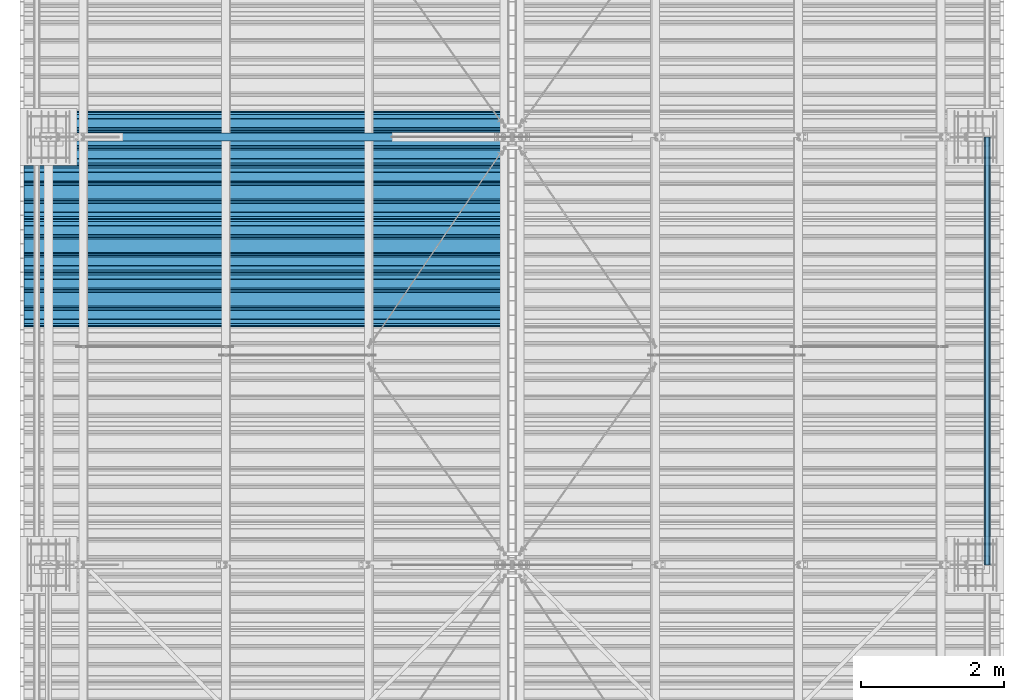
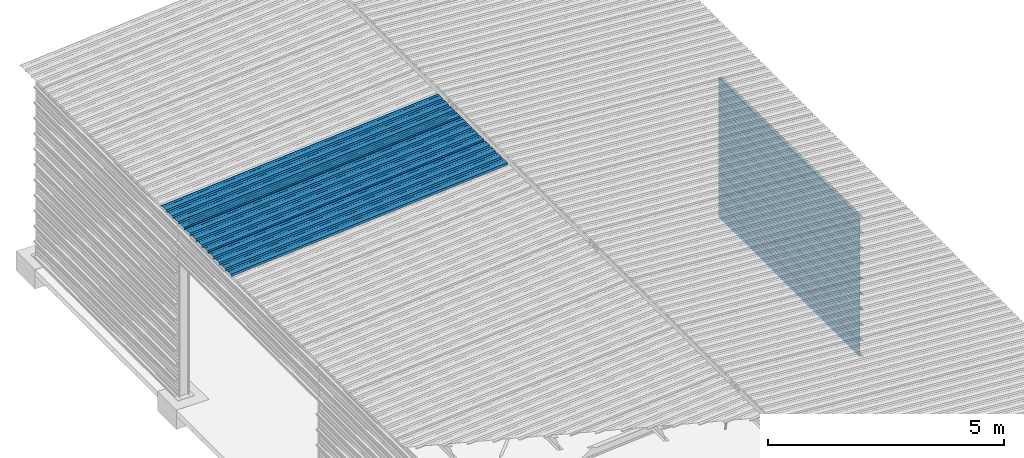
# One storey, part 15 of 70: 13 beams, 13 elements without a shape of their own.
"""IFC2X3 building model written with IfcOpenShell, lengths in millimetres."""

import ifcopenshell
import ifcopenshell.guid

model = None  # the IFC model being written
_history = None  # IfcOwnerHistory: only IFC2X3 demands one
_inside = {}  # id of a spatial element -> (the spatial element, [elements in it])
_under = {}  # id of a project, library or spatial element -> (it, [spatial elements below it])
_declared = {}  # id of a project -> (the project, [libraries it declares])
_typed = {}  # id of a type object -> (the type object, [elements of that type])
_made_of = {}  # id of a material, layer set ... -> (it, [elements and type objects made of it])


def new_model(schema):
    """Start an empty IFC model of exactly this schema.

    Asked for "IFC4X3", IfcOpenShell would pick the latest addendum, in which some entities
    have other attributes; the version numbers below select the first issue.
    IFC2X3 requires an IfcOwnerHistory on every rooted entity: one is made here for all.
    """
    global model, _history
    if schema == "IFC4X3":
        model = ifcopenshell.file(schema_version=(4, 3, 0, 0))
    else:
        model = ifcopenshell.file(schema=schema)
    _inside.clear()
    _under.clear()
    _declared.clear()
    _typed.clear()
    _made_of.clear()
    _history = None
    if model.schema == "IFC2X3":
        org = make("IfcOrganization", Name="unknown")
        user = make(
            "IfcPersonAndOrganization",
            ThePerson=make("IfcPerson", FamilyName="unknown"),
            TheOrganization=org,
        )
        app = make(
            "IfcApplication",
            ApplicationDeveloper=org,
            Version="unknown",
            ApplicationFullName="unknown",
            ApplicationIdentifier="unknown",
        )
        _history = make(
            "IfcOwnerHistory",
            OwningUser=user,
            OwningApplication=app,
            ChangeAction="ADDED",
            CreationDate=0,
        )
    return model


def make(cls, **values):
    """One entity of the class cls with the attributes given. An attribute that is None is left unset."""
    return model.create_entity(
        cls, **{name: value for name, value in values.items() if value is not None}
    )


def rooted(cls, **values):
    """An entity with a GlobalId (a new one), such as an element, a storey or a relation."""
    return make(cls, GlobalId=ifcopenshell.guid.new(), OwnerHistory=_history, **values)


def si_unit(unit_type, name, prefix=None):
    """IfcSIUnit, for example si_unit("LENGTHUNIT", "METRE", prefix="MILLI")."""
    return make("IfcSIUnit", UnitType=unit_type, Prefix=prefix, Name=name)


def assignment(units):
    """IfcUnitAssignment: the units of a project."""
    return None if units is None else make("IfcUnitAssignment", Units=units)


def point(xyz):
    """IfcCartesianPoint."""
    return None if xyz is None else make("IfcCartesianPoint", Coordinates=xyz)


def direction(xyz):
    """IfcDirection."""
    return None if xyz is None else make("IfcDirection", DirectionRatios=xyz)


def frame(location, z_axis=None, x_axis=None):
    """IfcAxis2Placement3D, a coordinate frame: its origin and axes. An axis left out is left unset."""
    return make(
        "IfcAxis2Placement3D",
        Location=point(location),
        Axis=direction(z_axis),
        RefDirection=direction(x_axis),
    )


def frame_2d(location, x_axis=None):
    """IfcAxis2Placement2D, a coordinate frame in the plane: its origin and x axis."""
    return make(
        "IfcAxis2Placement2D", Location=point(location), RefDirection=direction(x_axis)
    )


def origin_with_axes():
    """The frame at (0, 0, 0) with the z axis (0, 0, 1) and the x axis (1, 0, 0) written out."""
    return frame((0.0, 0.0, 0.0), z_axis=(0.0, 0.0, 1.0), x_axis=(1.0, 0.0, 0.0))


def origin_2d_with_axis():
    """The frame at (0, 0) in the plane with the x axis (1, 0) written out."""
    return frame_2d((0.0, 0.0), x_axis=(1.0, 0.0))


def place(relative_to, where):
    """IfcLocalPlacement: puts the frame where relative to a parent placement (None: the world)."""
    return make(
        "IfcLocalPlacement", PlacementRelTo=relative_to, RelativePlacement=where
    )


def context(
    kind, dimensions, precision=None, world=None, true_north=None, identifier=None
):
    """IfcGeometricRepresentationContext, for example the 3D "Model" context."""
    return make(
        "IfcGeometricRepresentationContext",
        ContextIdentifier=identifier,
        ContextType=kind,
        CoordinateSpaceDimension=dimensions,
        Precision=precision,
        WorldCoordinateSystem=world,
        TrueNorth=true_north,
    )


def subcontext(parent, identifier, kind, view, scale=None):
    """IfcGeometricRepresentationSubContext, for example "Body" below "Model"."""
    return make(
        "IfcGeometricRepresentationSubContext",
        ContextIdentifier=identifier,
        ContextType=kind,
        ParentContext=parent,
        TargetScale=scale,
        TargetView=view,
    )


def project(units=None, contexts=None):
    """IfcProject with its units and contexts."""
    return rooted(
        "IfcProject",
        Name="project",
        RepresentationContexts=contexts,
        UnitsInContext=assignment(units),
    )


def spatial(cls, under=None, at=None, **own):
    """A site, building, storey or space (cls), placed at a placement, below another one or the project."""
    s = rooted(cls, ObjectPlacement=at, **own)
    if under is not None:
        _under.setdefault(under.id(), (under, []))[1].append(s)
    return s


def polyline(points):
    """IfcPolyline through the points."""
    return make("IfcPolyline", Points=[point(p) for p in points])


def profile(cls, at=None, kind="AREA", **sizes):
    """A parametric profile (cls). Its sizes go by their IFC names, for example OverallWidth=200.0."""
    return make(cls, ProfileType=kind, Position=at, **sizes)


def i_section(**sizes):
    """IfcIShapeProfileDef."""
    return profile("IfcIShapeProfileDef", **sizes)


def outline(outer, holes=None, kind="AREA"):
    """IfcArbitraryClosedProfileDef: a profile drawn as a closed curve; with holes, ...WithVoids."""
    if holes is None:
        return make("IfcArbitraryClosedProfileDef", ProfileType=kind, OuterCurve=outer)
    return make(
        "IfcArbitraryProfileDefWithVoids",
        ProfileType=kind,
        OuterCurve=outer,
        InnerCurves=holes,
    )


def extrude(swept, where, along, depth):
    """IfcExtrudedAreaSolid: the profile swept, set in the frame where, extruded along a direction by depth."""
    return make(
        "IfcExtrudedAreaSolid",
        SweptArea=swept,
        Position=where,
        ExtrudedDirection=direction(along),
        Depth=depth,
    )


def clip(a, b, op="DIFFERENCE"):
    """IfcBooleanClippingResult: the solid a cut by the half space b."""
    return make(
        "IfcBooleanClippingResult", Operator=op, FirstOperand=a, SecondOperand=b
    )


def halfspace(plane, agree):
    """IfcHalfSpaceSolid: all space on one side of the plane z = 0 of the frame plane."""
    return make(
        "IfcHalfSpaceSolid",
        BaseSurface=make("IfcPlane", Position=plane),
        AgreementFlag=agree,
    )


def shape(context_of_items, identifier, shape_type, items):
    """IfcShapeRepresentation: the items that make up one representation, for example the "Body"."""
    return make(
        "IfcShapeRepresentation",
        ContextOfItems=context_of_items,
        RepresentationIdentifier=identifier,
        RepresentationType=shape_type,
        Items=items,
    )


def material(Name=None, Category=None):
    """IfcMaterial."""
    return make("IfcMaterial", Name=Name, Category=Category)


def made_of(thing, what):
    """Note that an element or type object is made of a material, layer set ...; save() writes the relation."""
    if what is not None:
        _made_of.setdefault(what.id(), (what, []))[1].append(thing)
    return thing


def type_object(cls, material=None, **own):
    """A type object (cls), such as IfcWallType, which elements share."""
    return made_of(rooted(cls, **own), material)


def element(
    cls,
    number,
    at=None,
    inside=None,
    cuts=None,
    type_object=None,
    material=None,
    context=None,
    identifier="Body",
    shape_type=None,
    held_by="IfcProductDefinitionShape",
    body=None,
    shapes=None,
    **own,
):
    """One element of the class cls, such as IfcWall. Its Tag is "e" and its number.

    at: its placement. inside: the storey or other place that contains it. cuts: it is an
    opening in that element (IfcRelVoidsElement). A single representation is given by context,
    identifier, shape_type and body (its items); several are given by shapes. held_by: the class
    of the entity that holds the representations. save() writes the other relations.
    """
    e = rooted(cls, Tag="e%d" % number, ObjectPlacement=at, **own)
    if body is not None:
        shapes = [shape(context, identifier, shape_type, body)]
    if shapes is not None:
        e.Representation = make(held_by, Representations=shapes)
    if inside is not None:
        _inside.setdefault(inside.id(), (inside, []))[1].append(e)
    if cuts is not None:
        rooted(
            "IfcRelVoidsElement", RelatingBuildingElement=cuts, RelatedOpeningElement=e
        )
    if type_object is not None:
        _typed.setdefault(type_object.id(), (type_object, []))[1].append(e)
    return made_of(e, material)


def aggregate(whole, parts):
    """IfcRelAggregates: a whole, such as a stair, and the parts it consists of."""
    return rooted("IfcRelAggregates", RelatingObject=whole, RelatedObjects=parts)


def save(model, path):
    """Write the relations noted so far, then the file.

    IfcRelAggregates (storeys below a building ...), IfcRelContainedInSpatialStructure (elements
    in a storey), IfcRelDefinesByType, IfcRelAssociatesMaterial and IfcRelDeclares: one each for
    every whole, place, type object, material and project.
    """
    for whole, parts in _under.values():
        aggregate(whole, parts)
    for where, things in _inside.values():
        rooted(
            "IfcRelContainedInSpatialStructure",
            RelatedElements=things,
            RelatingStructure=where,
        )
    for kind, things in _typed.values():
        rooted("IfcRelDefinesByType", RelatedObjects=things, RelatingType=kind)
    for what, things in _made_of.values():
        rooted("IfcRelAssociatesMaterial", RelatedObjects=things, RelatingMaterial=what)
    for by, libraries in _declared.values():
        rooted("IfcRelDeclares", RelatingContext=by, RelatedDefinitions=libraries)
    model.write(path)


model = new_model("IFC2X3")

# Units and contexts
model_context = context("Model", 3, precision=1e-05, world=origin_with_axes())
body_context = subcontext(model_context, "Body", "Model", "MODEL_VIEW")
ifc_project = project(units=[si_unit("LENGTHUNIT", "METRE", prefix="MILLI"), si_unit("AREAUNIT", "SQUARE_METRE"), si_unit("VOLUMEUNIT", "CUBIC_METRE"), si_unit("MASSUNIT", "GRAM", prefix="KILO"), si_unit("TIMEUNIT", "SECOND"), si_unit("PLANEANGLEUNIT", "RADIAN"), si_unit("SOLIDANGLEUNIT", "STERADIAN"), si_unit("THERMODYNAMICTEMPERATUREUNIT", "DEGREE_CELSIUS"), si_unit("LUMINOUSINTENSITYUNIT", "LUMEN")], contexts=[model_context])

# Site, building, storey
site_placement = place(None, origin_with_axes())
site = spatial("IfcSite", under=ifc_project, at=site_placement, CompositionType="ELEMENT")
building_placement = place(site_placement, origin_with_axes())
building = spatial("IfcBuilding", under=site, at=building_placement, Name="Undefined", CompositionType="ELEMENT")
storey_placement = place(building_placement, origin_with_axes())
storey = spatial("IfcBuildingStorey", under=building, at=storey_placement, Name="Undefined", CompositionType="ELEMENT", Elevation=0.0)

# Assembly, beam
assembly_1_placement = place(storey_placement, origin_with_axes())
assembly_1 = element("IfcElementAssembly", 1, at=assembly_1_placement, inside=storey, Name="Steel Assembly", AssemblyPlace="NOTDEFINED", PredefinedType="RIGID_FRAME")
ifc_material = material(Name="STEEL/S235JR")
beam_type_1 = type_object("IfcBeamType", Name="4.40", PredefinedType="NOTDEFINED")
beam_1_placement = place(assembly_1_placement, frame((6436.39248868039, 15850.0, 5336.31760454388), z_axis=(0.0766964990376782, 0.0, -0.997054485489817), x_axis=(-0.997054485489818, 0.0, -0.0766964990376602)))
beam_1 = element("IfcBeam", 2, at=beam_1_placement, type_object=beam_type_1, material=ifc_material, ObjectType="4.40", context=body_context, shape_type="SweptSolid", body=[
    extrude(outline(polyline([(509.415161132813, 19.5000000011705), (490.584838867188, 19.5000000011705), (468.084838867188, -20.4999999988113), (406.585784912109, -20.4999999988113), (404.585784912109, -18.4999999988122), (345.414215087891, -18.4999999988122), (343.414215087891, -20.4999999988113), (281.915161132813, -20.4999999988113), (259.415161132813, 19.5000000011705), (240.584854125977, 19.5000000011705), (218.084854125977, -20.4999999988113), (156.585784912109, -20.4999999988113), (154.585784912109, -18.4999999988122), (95.4142150878906, -18.4999999988122), (93.4142150878906, -20.4999999988113), (31.9151515960693, -20.4999999988113), (9.41515254974365, 19.5000000011705), (-9.41515254974365, 19.5000000011705), (-31.9151515960693, -20.4999999988113), (-93.4142150878906, -20.4999999988113), (-95.4142150878906, -18.4999999988122), (-154.585784912109, -18.4999999988122), (-156.585784912109, -20.4999999988113), (-218.084854125977, -20.4999999988113), (-240.584854125977, 19.5000000011705), (-259.415161132813, 19.5000000011705), (-281.915161132813, -20.4999999988113), (-343.414215087891, -20.4999999988113), (-345.414215087891, -18.4999999988122), (-404.585784912109, -18.4999999988122), (-406.585784912109, -20.4999999988113), (-468.084838867188, -20.4999999988113), (-490.584838867188, 19.5000000011705), (-509.415161132813, 19.5000000011705), (-516.482360839844, 6.9361057293263), (-517.353942871094, 7.42636680720625), (-510.0, 20.5000000011705), (-490.0, 20.5000000011705), (-467.5, -19.4999999988122), (-407.0, -19.4999999988122), (-405.0, -17.4999999988131), (-345.0, -17.4999999988131), (-343.0, -19.4999999988122), (-282.5, -19.4999999988122), (-260.0, 20.5000000011705), (-240.0, 20.5000000011705), (-217.5, -19.4999999988122), (-157.0, -19.4999999988122), (-155.0, -17.4999999988131), (-95.0, -17.4999999988131), (-93.0, -19.4999999988122), (-32.5, -19.4999999988122), (-10.0, 20.5000000011705), (10.0, 20.5000000011705), (32.5, -19.4999999988122), (93.0, -19.4999999988122), (95.0, -17.4999999988131), (155.0, -17.4999999988131), (157.0, -19.4999999988122), (217.5, -19.4999999988122), (240.0, 20.5000000011705), (260.0, 20.5000000011705), (282.5, -19.4999999988122), (343.0, -19.4999999988122), (345.0, -17.4999999988131), (405.0, -17.4999999988131), (407.0, -19.4999999988122), (467.5, -19.4999999988122), (490.0, 20.5000000011705), (510.0, 20.5000000011705), (517.353942871094, 7.42636680720625), (516.482360839844, 6.9361057293263), (509.415161132813, 19.5000000011705)])), frame((6799.99999999733, 2.8421709430404e-14, 0.0), z_axis=(-1.0, 0.0, 0.0), x_axis=(0.0, -1.0, 0.0)), (0.0, 0.0, 1.0), 6800.0),
])
aggregate(assembly_1, [beam_1])

assembly_2_placement = place(storey_placement, origin_with_axes())
assembly_2 = element("IfcElementAssembly", 3, at=assembly_2_placement, inside=storey, Name="Steel Assembly", AssemblyPlace="NOTDEFINED", PredefinedType="RIGID_FRAME")
beam_2_placement = place(assembly_2_placement, frame((6436.39248868039, 16850.0, 5336.31760454388), z_axis=(0.0766964990376782, 0.0, -0.997054485489817), x_axis=(-0.997054485489818, 0.0, -0.0766964990376602)))
beam_2 = element("IfcBeam", 4, at=beam_2_placement, type_object=beam_type_1, material=ifc_material, ObjectType="4.40", context=body_context, shape_type="SweptSolid", body=[
    extrude(outline(polyline([(509.415161132813, 19.5000000011705), (490.584838867188, 19.5000000011705), (468.084838867188, -20.4999999988113), (406.585784912109, -20.4999999988113), (404.585784912109, -18.4999999988122), (345.414215087891, -18.4999999988122), (343.414215087891, -20.4999999988113), (281.915161132813, -20.4999999988113), (259.415161132813, 19.5000000011705), (240.584854125977, 19.5000000011705), (218.084854125977, -20.4999999988113), (156.585784912109, -20.4999999988113), (154.585784912109, -18.4999999988122), (95.4142150878906, -18.4999999988122), (93.4142150878906, -20.4999999988113), (31.9151515960693, -20.4999999988113), (9.41515254974365, 19.5000000011705), (-9.41515254974365, 19.5000000011705), (-31.9151515960693, -20.4999999988113), (-93.4142150878906, -20.4999999988113), (-95.4142150878906, -18.4999999988122), (-154.585784912109, -18.4999999988122), (-156.585784912109, -20.4999999988113), (-218.084854125977, -20.4999999988113), (-240.584854125977, 19.5000000011705), (-259.415161132813, 19.5000000011705), (-281.915161132813, -20.4999999988113), (-343.414215087891, -20.4999999988113), (-345.414215087891, -18.4999999988122), (-404.585784912109, -18.4999999988122), (-406.585784912109, -20.4999999988113), (-468.084838867188, -20.4999999988113), (-490.584838867188, 19.5000000011705), (-509.415161132813, 19.5000000011705), (-516.482360839844, 6.9361057293263), (-517.353942871094, 7.42636680720625), (-510.0, 20.5000000011705), (-490.0, 20.5000000011705), (-467.5, -19.4999999988122), (-407.0, -19.4999999988122), (-405.0, -17.4999999988131), (-345.0, -17.4999999988131), (-343.0, -19.4999999988122), (-282.5, -19.4999999988122), (-260.0, 20.5000000011705), (-240.0, 20.5000000011705), (-217.5, -19.4999999988122), (-157.0, -19.4999999988122), (-155.0, -17.4999999988131), (-95.0, -17.4999999988131), (-93.0, -19.4999999988122), (-32.5, -19.4999999988122), (-10.0, 20.5000000011705), (10.0, 20.5000000011705), (32.5, -19.4999999988122), (93.0, -19.4999999988122), (95.0, -17.4999999988131), (155.0, -17.4999999988131), (157.0, -19.4999999988122), (217.5, -19.4999999988122), (240.0, 20.5000000011705), (260.0, 20.5000000011705), (282.5, -19.4999999988122), (343.0, -19.4999999988122), (345.0, -17.4999999988131), (405.0, -17.4999999988131), (407.0, -19.4999999988122), (467.5, -19.4999999988122), (490.0, 20.5000000011705), (510.0, 20.5000000011705), (517.353942871094, 7.42636680720625), (516.482360839844, 6.9361057293263), (509.415161132813, 19.5000000011705)])), frame((6799.99999999733, 2.8421709430404e-14, 0.0), z_axis=(-1.0, 0.0, 0.0), x_axis=(0.0, -1.0, 0.0)), (0.0, 0.0, 1.0), 6800.0),
])
aggregate(assembly_2, [beam_2])

assembly_3_placement = place(storey_placement, origin_with_axes())
assembly_3 = element("IfcElementAssembly", 5, at=assembly_3_placement, inside=storey, Name="Steel Assembly", AssemblyPlace="NOTDEFINED", PredefinedType="RIGID_FRAME")
beam_3_placement = place(assembly_3_placement, frame((6436.39248868039, 17850.0, 5336.31760454388), z_axis=(0.0766964990376782, 0.0, -0.997054485489817), x_axis=(-0.997054485489818, 0.0, -0.0766964990376602)))
beam_3 = element("IfcBeam", 6, at=beam_3_placement, type_object=beam_type_1, material=ifc_material, ObjectType="4.40", context=body_context, shape_type="SweptSolid", body=[
    extrude(outline(polyline([(509.415161132813, 19.5000000011705), (490.584838867188, 19.5000000011705), (468.084838867188, -20.4999999988113), (406.585784912109, -20.4999999988113), (404.585784912109, -18.4999999988122), (345.414215087891, -18.4999999988122), (343.414215087891, -20.4999999988113), (281.915161132813, -20.4999999988113), (259.415161132813, 19.5000000011705), (240.584854125977, 19.5000000011705), (218.084854125977, -20.4999999988113), (156.585784912109, -20.4999999988113), (154.585784912109, -18.4999999988122), (95.4142150878906, -18.4999999988122), (93.4142150878906, -20.4999999988113), (31.9151515960693, -20.4999999988113), (9.41515254974365, 19.5000000011705), (-9.41515254974365, 19.5000000011705), (-31.9151515960693, -20.4999999988113), (-93.4142150878906, -20.4999999988113), (-95.4142150878906, -18.4999999988122), (-154.585784912109, -18.4999999988122), (-156.585784912109, -20.4999999988113), (-218.084854125977, -20.4999999988113), (-240.584854125977, 19.5000000011705), (-259.415161132813, 19.5000000011705), (-281.915161132813, -20.4999999988113), (-343.414215087891, -20.4999999988113), (-345.414215087891, -18.4999999988122), (-404.585784912109, -18.4999999988122), (-406.585784912109, -20.4999999988113), (-468.084838867188, -20.4999999988113), (-490.584838867188, 19.5000000011705), (-509.415161132813, 19.5000000011705), (-516.482360839844, 6.9361057293263), (-517.353942871094, 7.42636680720625), (-510.0, 20.5000000011705), (-490.0, 20.5000000011705), (-467.5, -19.4999999988122), (-407.0, -19.4999999988122), (-405.0, -17.4999999988131), (-345.0, -17.4999999988131), (-343.0, -19.4999999988122), (-282.5, -19.4999999988122), (-260.0, 20.5000000011705), (-240.0, 20.5000000011705), (-217.5, -19.4999999988122), (-157.0, -19.4999999988122), (-155.0, -17.4999999988131), (-95.0, -17.4999999988131), (-93.0, -19.4999999988122), (-32.5, -19.4999999988122), (-10.0, 20.5000000011705), (10.0, 20.5000000011705), (32.5, -19.4999999988122), (93.0, -19.4999999988122), (95.0, -17.4999999988131), (155.0, -17.4999999988131), (157.0, -19.4999999988122), (217.5, -19.4999999988122), (240.0, 20.5000000011705), (260.0, 20.5000000011705), (282.5, -19.4999999988122), (343.0, -19.4999999988122), (345.0, -17.4999999988131), (405.0, -17.4999999988131), (407.0, -19.4999999988122), (467.5, -19.4999999988122), (490.0, 20.5000000011705), (510.0, 20.5000000011705), (517.353942871094, 7.42636680720625), (516.482360839844, 6.9361057293263), (509.415161132813, 19.5000000011705)])), frame((6799.99999999733, 2.8421709430404e-14, 0.0), z_axis=(-1.0, 0.0, 0.0), x_axis=(0.0, -1.0, 0.0)), (0.0, 0.0, 1.0), 6800.0),
])
aggregate(assembly_3, [beam_3])

assembly_4_placement = place(storey_placement, origin_with_axes())
assembly_4 = element("IfcElementAssembly", 7, at=assembly_4_placement, inside=storey, Name="Steel Assembly", AssemblyPlace="NOTDEFINED", PredefinedType="RIGID_FRAME")
beam_type_2 = type_object("IfcBeamType", Name="400", PredefinedType="NOTDEFINED")
beam_4_placement = place(assembly_4_placement, frame((13165.4999999988, 18000.0, 3418.17396601053), z_axis=(1.0, 0.0, 0.0), x_axis=(0.0, -1.0, 0.0)))
beam_4 = element("IfcBeam", 8, at=beam_4_placement, type_object=beam_type_2, material=ifc_material, ObjectType="400", context=body_context, shape_type="SweptSolid", body=[
    extrude(outline(polyline([(218.25, -24.994083404541), (214.25, -31.8999996185303), (214.25, -45.5), (199.75, -45.5), (194.25, -42.5), (188.75, -45.5), (124.25, -45.5), (114.25, -41.5), (104.25, -45.5), (24.25, -45.5), (14.25, -41.5), (4.25, -45.5), (-75.75, -45.5), (-85.75, -41.5), (-95.75, -45.5), (-160.25, -45.5), (-165.75, -42.5), (-171.25, -45.5), (-185.75, -45.5), (-185.75, -30.711540222168), (-181.75, -23.8111782073975), (-181.75, 23.311637878418), (-185.75, 30.2119998931885), (-185.75, 44.5), (-217.25, 44.5), (-217.25, 34.7999992370605), (-218.25, 34.7999992370605), (-218.25, 45.5), (-184.75, 45.5), (-184.75, 30.480884552002), (-180.75, 23.5805225372314), (-180.75, -24.0800628662109), (-184.75, -30.9804248809814), (-184.75, -44.5), (-171.504989624023, -44.5), (-165.75, -41.360912322998), (-159.995010375977, -44.5), (-95.9425811767578, -44.5), (-85.75, -40.422966003418), (-75.5574188232422, -44.5), (4.05741739273071, -44.5), (14.25, -40.422966003418), (24.4425830841064, -44.5), (104.057418823242, -44.5), (114.25, -40.422966003418), (124.442581176758, -44.5), (188.495010375977, -44.5), (194.25, -41.360912322998), (200.004989624023, -44.5), (213.25, -44.5), (213.25, -31.6313018798828), (217.25, -24.7253856658936), (217.25, 21.7253856658936), (213.25, 28.6313018798828), (213.25, 42.0), (187.25, 42.0), (187.25, 32.5499992370605), (186.25, 32.5499992370605), (186.25, 43.0), (214.25, 43.0), (214.25, 28.8999996185303), (218.25, 21.994083404541), (218.25, -24.994083404541)])), frame((6000.0, 0.0, 0.0), z_axis=(-1.0, 0.0, 0.0), x_axis=(0.0, -1.0, 0.0)), (0.0, 0.0, 1.0), 6000.0),
])
aggregate(assembly_4, [beam_4])

assembly_5_placement = place(storey_placement, origin_with_axes())
assembly_5 = element("IfcElementAssembly", 9, at=assembly_5_placement, inside=storey, Name="Steel Assembly", AssemblyPlace="NOTDEFINED", PredefinedType="RIGID_FRAME")
beam_5_placement = place(assembly_5_placement, frame((13165.4999999989, 18000.0, 3018.17396601053), z_axis=(1.0, 0.0, 0.0), x_axis=(0.0, -1.0, 0.0)))
beam_5 = element("IfcBeam", 10, at=beam_5_placement, type_object=beam_type_2, material=ifc_material, ObjectType="400", context=body_context, shape_type="SweptSolid", body=[
    extrude(outline(polyline([(218.25, -24.994083404541), (214.25, -31.8999996185303), (214.25, -45.5), (199.75, -45.5), (194.25, -42.5), (188.75, -45.5), (124.25, -45.5), (114.25, -41.5), (104.25, -45.5), (24.25, -45.5), (14.25, -41.5), (4.25, -45.5), (-75.75, -45.5), (-85.75, -41.5), (-95.75, -45.5), (-160.25, -45.5), (-165.75, -42.5), (-171.25, -45.5), (-185.75, -45.5), (-185.75, -30.711540222168), (-181.75, -23.8111782073975), (-181.75, 23.311637878418), (-185.75, 30.2119998931885), (-185.75, 44.5), (-217.25, 44.5), (-217.25, 34.7999992370605), (-218.25, 34.7999992370605), (-218.25, 45.5), (-184.75, 45.5), (-184.75, 30.480884552002), (-180.75, 23.5805225372314), (-180.75, -24.0800628662109), (-184.75, -30.9804248809814), (-184.75, -44.5), (-171.504989624023, -44.5), (-165.75, -41.360912322998), (-159.995010375977, -44.5), (-95.9425811767578, -44.5), (-85.75, -40.422966003418), (-75.5574188232422, -44.5), (4.05741739273071, -44.5), (14.25, -40.422966003418), (24.4425830841064, -44.5), (104.057418823242, -44.5), (114.25, -40.422966003418), (124.442581176758, -44.5), (188.495010375977, -44.5), (194.25, -41.360912322998), (200.004989624023, -44.5), (213.25, -44.5), (213.25, -31.6313018798828), (217.25, -24.7253856658936), (217.25, 21.7253856658936), (213.25, 28.6313018798828), (213.25, 42.0), (187.25, 42.0), (187.25, 32.5499992370605), (186.25, 32.5499992370605), (186.25, 43.0), (214.25, 43.0), (214.25, 28.8999996185303), (218.25, 21.994083404541), (218.25, -24.994083404541)])), frame((6000.0, 0.0, 0.0), z_axis=(-1.0, 0.0, 0.0), x_axis=(0.0, -1.0, 0.0)), (0.0, 0.0, 1.0), 6000.0),
])
aggregate(assembly_5, [beam_5])

assembly_6_placement = place(storey_placement, origin_with_axes())
assembly_6 = element("IfcElementAssembly", 11, at=assembly_6_placement, inside=storey, Name="Steel Assembly", AssemblyPlace="NOTDEFINED", PredefinedType="RIGID_FRAME")
beam_6_placement = place(assembly_6_placement, frame((13165.4999999991, 18000.0, 2618.17396601053), z_axis=(1.0, 0.0, 0.0), x_axis=(0.0, -1.0, 0.0)))
beam_6 = element("IfcBeam", 12, at=beam_6_placement, type_object=beam_type_2, material=ifc_material, ObjectType="400", context=body_context, shape_type="SweptSolid", body=[
    extrude(outline(polyline([(218.25, -24.994083404541), (214.25, -31.8999996185303), (214.25, -45.5), (199.75, -45.5), (194.25, -42.5), (188.75, -45.5), (124.25, -45.5), (114.25, -41.5), (104.25, -45.5), (24.25, -45.5), (14.25, -41.5), (4.25, -45.5), (-75.75, -45.5), (-85.75, -41.5), (-95.75, -45.5), (-160.25, -45.5), (-165.75, -42.5), (-171.25, -45.5), (-185.75, -45.5), (-185.75, -30.711540222168), (-181.75, -23.8111782073975), (-181.75, 23.311637878418), (-185.75, 30.2119998931885), (-185.75, 44.5), (-217.25, 44.5), (-217.25, 34.7999992370605), (-218.25, 34.7999992370605), (-218.25, 45.5), (-184.75, 45.5), (-184.75, 30.480884552002), (-180.75, 23.5805225372314), (-180.75, -24.0800628662109), (-184.75, -30.9804248809814), (-184.75, -44.5), (-171.504989624023, -44.5), (-165.75, -41.360912322998), (-159.995010375977, -44.5), (-95.9425811767578, -44.5), (-85.75, -40.422966003418), (-75.5574188232422, -44.5), (4.05741739273071, -44.5), (14.25, -40.422966003418), (24.4425830841064, -44.5), (104.057418823242, -44.5), (114.25, -40.422966003418), (124.442581176758, -44.5), (188.495010375977, -44.5), (194.25, -41.360912322998), (200.004989624023, -44.5), (213.25, -44.5), (213.25, -31.6313018798828), (217.25, -24.7253856658936), (217.25, 21.7253856658936), (213.25, 28.6313018798828), (213.25, 42.0), (187.25, 42.0), (187.25, 32.5499992370605), (186.25, 32.5499992370605), (186.25, 43.0), (214.25, 43.0), (214.25, 28.8999996185303), (218.25, 21.994083404541), (218.25, -24.994083404541)])), frame((6000.0, 0.0, 0.0), z_axis=(-1.0, 0.0, 0.0), x_axis=(0.0, -1.0, 0.0)), (0.0, 0.0, 1.0), 6000.0),
])
aggregate(assembly_6, [beam_6])

assembly_7_placement = place(storey_placement, origin_with_axes())
assembly_7 = element("IfcElementAssembly", 13, at=assembly_7_placement, inside=storey, Name="Steel Assembly", AssemblyPlace="NOTDEFINED", PredefinedType="RIGID_FRAME")
beam_7_placement = place(assembly_7_placement, frame((13165.4999999992, 18000.0, 2218.17396601053), z_axis=(1.0, 0.0, 0.0), x_axis=(0.0, -1.0, 0.0)))
beam_7 = element("IfcBeam", 14, at=beam_7_placement, type_object=beam_type_2, material=ifc_material, ObjectType="400", context=body_context, shape_type="SweptSolid", body=[
    extrude(outline(polyline([(218.25, -24.994083404541), (214.25, -31.8999996185303), (214.25, -45.5), (199.75, -45.5), (194.25, -42.5), (188.75, -45.5), (124.25, -45.5), (114.25, -41.5), (104.25, -45.5), (24.25, -45.5), (14.25, -41.5), (4.25, -45.5), (-75.75, -45.5), (-85.75, -41.5), (-95.75, -45.5), (-160.25, -45.5), (-165.75, -42.5), (-171.25, -45.5), (-185.75, -45.5), (-185.75, -30.711540222168), (-181.75, -23.8111782073975), (-181.75, 23.311637878418), (-185.75, 30.2119998931885), (-185.75, 44.5), (-217.25, 44.5), (-217.25, 34.7999992370605), (-218.25, 34.7999992370605), (-218.25, 45.5), (-184.75, 45.5), (-184.75, 30.480884552002), (-180.75, 23.5805225372314), (-180.75, -24.0800628662109), (-184.75, -30.9804248809814), (-184.75, -44.5), (-171.504989624023, -44.5), (-165.75, -41.360912322998), (-159.995010375977, -44.5), (-95.9425811767578, -44.5), (-85.75, -40.422966003418), (-75.5574188232422, -44.5), (4.05741739273071, -44.5), (14.25, -40.422966003418), (24.4425830841064, -44.5), (104.057418823242, -44.5), (114.25, -40.422966003418), (124.442581176758, -44.5), (188.495010375977, -44.5), (194.25, -41.360912322998), (200.004989624023, -44.5), (213.25, -44.5), (213.25, -31.6313018798828), (217.25, -24.7253856658936), (217.25, 21.7253856658936), (213.25, 28.6313018798828), (213.25, 42.0), (187.25, 42.0), (187.25, 32.5499992370605), (186.25, 32.5499992370605), (186.25, 43.0), (214.25, 43.0), (214.25, 28.8999996185303), (218.25, 21.994083404541), (218.25, -24.994083404541)])), frame((6000.0, 0.0, 0.0), z_axis=(-1.0, 0.0, 0.0), x_axis=(0.0, -1.0, 0.0)), (0.0, 0.0, 1.0), 6000.0),
])
aggregate(assembly_7, [beam_7])

assembly_8_placement = place(storey_placement, origin_with_axes())
assembly_8 = element("IfcElementAssembly", 15, at=assembly_8_placement, inside=storey, Name="Steel Assembly", AssemblyPlace="NOTDEFINED", PredefinedType="RIGID_FRAME")
beam_8_placement = place(assembly_8_placement, frame((13165.4999999994, 18000.0, 1818.17396601053), z_axis=(1.0, 0.0, 0.0), x_axis=(0.0, -1.0, 0.0)))
beam_8 = element("IfcBeam", 16, at=beam_8_placement, type_object=beam_type_2, material=ifc_material, ObjectType="400", context=body_context, shape_type="SweptSolid", body=[
    extrude(outline(polyline([(218.25, -24.994083404541), (214.25, -31.8999996185303), (214.25, -45.5), (199.75, -45.5), (194.25, -42.5), (188.75, -45.5), (124.25, -45.5), (114.25, -41.5), (104.25, -45.5), (24.25, -45.5), (14.25, -41.5), (4.25, -45.5), (-75.75, -45.5), (-85.75, -41.5), (-95.75, -45.5), (-160.25, -45.5), (-165.75, -42.5), (-171.25, -45.5), (-185.75, -45.5), (-185.75, -30.711540222168), (-181.75, -23.8111782073975), (-181.75, 23.311637878418), (-185.75, 30.2119998931885), (-185.75, 44.5), (-217.25, 44.5), (-217.25, 34.7999992370605), (-218.25, 34.7999992370605), (-218.25, 45.5), (-184.75, 45.5), (-184.75, 30.480884552002), (-180.75, 23.5805225372314), (-180.75, -24.0800628662109), (-184.75, -30.9804248809814), (-184.75, -44.5), (-171.504989624023, -44.5), (-165.75, -41.360912322998), (-159.995010375977, -44.5), (-95.9425811767578, -44.5), (-85.75, -40.422966003418), (-75.5574188232422, -44.5), (4.05741739273071, -44.5), (14.25, -40.422966003418), (24.4425830841064, -44.5), (104.057418823242, -44.5), (114.25, -40.422966003418), (124.442581176758, -44.5), (188.495010375977, -44.5), (194.25, -41.360912322998), (200.004989624023, -44.5), (213.25, -44.5), (213.25, -31.6313018798828), (217.25, -24.7253856658936), (217.25, 21.7253856658936), (213.25, 28.6313018798828), (213.25, 42.0), (187.25, 42.0), (187.25, 32.5499992370605), (186.25, 32.5499992370605), (186.25, 43.0), (214.25, 43.0), (214.25, 28.8999996185303), (218.25, 21.994083404541), (218.25, -24.994083404541)])), frame((6000.0, 0.0, 0.0), z_axis=(-1.0, 0.0, 0.0), x_axis=(0.0, -1.0, 0.0)), (0.0, 0.0, 1.0), 6000.0),
])
aggregate(assembly_8, [beam_8])

assembly_9_placement = place(storey_placement, origin_with_axes())
assembly_9 = element("IfcElementAssembly", 17, at=assembly_9_placement, inside=storey, Name="Steel Assembly", AssemblyPlace="NOTDEFINED", PredefinedType="RIGID_FRAME")
beam_9_placement = place(assembly_9_placement, frame((13165.4999999995, 18000.0, 1418.17396601053), z_axis=(1.0, 0.0, 0.0), x_axis=(0.0, -1.0, 0.0)))
beam_9 = element("IfcBeam", 18, at=beam_9_placement, type_object=beam_type_2, material=ifc_material, ObjectType="400", context=body_context, shape_type="SweptSolid", body=[
    extrude(outline(polyline([(218.25, -24.994083404541), (214.25, -31.8999996185303), (214.25, -45.5), (199.75, -45.5), (194.25, -42.5), (188.75, -45.5), (124.25, -45.5), (114.25, -41.5), (104.25, -45.5), (24.25, -45.5), (14.25, -41.5), (4.25, -45.5), (-75.75, -45.5), (-85.75, -41.5), (-95.75, -45.5), (-160.25, -45.5), (-165.75, -42.5), (-171.25, -45.5), (-185.75, -45.5), (-185.75, -30.711540222168), (-181.75, -23.8111782073975), (-181.75, 23.311637878418), (-185.75, 30.2119998931885), (-185.75, 44.5), (-217.25, 44.5), (-217.25, 34.7999992370605), (-218.25, 34.7999992370605), (-218.25, 45.5), (-184.75, 45.5), (-184.75, 30.480884552002), (-180.75, 23.5805225372314), (-180.75, -24.0800628662109), (-184.75, -30.9804248809814), (-184.75, -44.5), (-171.504989624023, -44.5), (-165.75, -41.360912322998), (-159.995010375977, -44.5), (-95.9425811767578, -44.5), (-85.75, -40.422966003418), (-75.5574188232422, -44.5), (4.05741739273071, -44.5), (14.25, -40.422966003418), (24.4425830841064, -44.5), (104.057418823242, -44.5), (114.25, -40.422966003418), (124.442581176758, -44.5), (188.495010375977, -44.5), (194.25, -41.360912322998), (200.004989624023, -44.5), (213.25, -44.5), (213.25, -31.6313018798828), (217.25, -24.7253856658936), (217.25, 21.7253856658936), (213.25, 28.6313018798828), (213.25, 42.0), (187.25, 42.0), (187.25, 32.5499992370605), (186.25, 32.5499992370605), (186.25, 43.0), (214.25, 43.0), (214.25, 28.8999996185303), (218.25, 21.994083404541), (218.25, -24.994083404541)])), frame((6000.0, 0.0, 0.0), z_axis=(-1.0, 0.0, 0.0), x_axis=(0.0, -1.0, 0.0)), (0.0, 0.0, 1.0), 6000.0),
])
aggregate(assembly_9, [beam_9])

assembly_10_placement = place(storey_placement, origin_with_axes())
assembly_10 = element("IfcElementAssembly", 19, at=assembly_10_placement, inside=storey, Name="Steel Assembly", AssemblyPlace="NOTDEFINED", PredefinedType="RIGID_FRAME")
beam_10_placement = place(assembly_10_placement, frame((13165.4999999997, 18000.0, 1018.17396601053), z_axis=(1.0, 0.0, 0.0), x_axis=(0.0, -1.0, 0.0)))
beam_10 = element("IfcBeam", 20, at=beam_10_placement, type_object=beam_type_2, material=ifc_material, ObjectType="400", context=body_context, shape_type="SweptSolid", body=[
    extrude(outline(polyline([(218.25, -24.994083404541), (214.25, -31.8999996185303), (214.25, -45.5), (199.75, -45.5), (194.25, -42.5), (188.75, -45.5), (124.25, -45.5), (114.25, -41.5), (104.25, -45.5), (24.25, -45.5), (14.25, -41.5), (4.25, -45.5), (-75.75, -45.5), (-85.75, -41.5), (-95.75, -45.5), (-160.25, -45.5), (-165.75, -42.5), (-171.25, -45.5), (-185.75, -45.5), (-185.75, -30.711540222168), (-181.75, -23.8111782073975), (-181.75, 23.311637878418), (-185.75, 30.2119998931885), (-185.75, 44.5), (-217.25, 44.5), (-217.25, 34.7999992370605), (-218.25, 34.7999992370605), (-218.25, 45.5), (-184.75, 45.5), (-184.75, 30.480884552002), (-180.75, 23.5805225372314), (-180.75, -24.0800628662109), (-184.75, -30.9804248809814), (-184.75, -44.5), (-171.504989624023, -44.5), (-165.75, -41.360912322998), (-159.995010375977, -44.5), (-95.9425811767578, -44.5), (-85.75, -40.422966003418), (-75.5574188232422, -44.5), (4.05741739273071, -44.5), (14.25, -40.422966003418), (24.4425830841064, -44.5), (104.057418823242, -44.5), (114.25, -40.422966003418), (124.442581176758, -44.5), (188.495010375977, -44.5), (194.25, -41.360912322998), (200.004989624023, -44.5), (213.25, -44.5), (213.25, -31.6313018798828), (217.25, -24.7253856658936), (217.25, 21.7253856658936), (213.25, 28.6313018798828), (213.25, 42.0), (187.25, 42.0), (187.25, 32.5499992370605), (186.25, 32.5499992370605), (186.25, 43.0), (214.25, 43.0), (214.25, 28.8999996185303), (218.25, 21.994083404541), (218.25, -24.994083404541)])), frame((6000.0, 0.0, 0.0), z_axis=(-1.0, 0.0, 0.0), x_axis=(0.0, -1.0, 0.0)), (0.0, 0.0, 1.0), 6000.0),
])
aggregate(assembly_10, [beam_10])

assembly_11_placement = place(storey_placement, origin_with_axes())
assembly_11 = element("IfcElementAssembly", 21, at=assembly_11_placement, inside=storey, Name="Steel Assembly", AssemblyPlace="NOTDEFINED", PredefinedType="RIGID_FRAME")
beam_11_placement = place(assembly_11_placement, frame((13165.4999999998, 18000.0, 618.173966010529), z_axis=(1.0, 0.0, 0.0), x_axis=(0.0, -1.0, 0.0)))
beam_11 = element("IfcBeam", 22, at=beam_11_placement, type_object=beam_type_2, material=ifc_material, ObjectType="400", context=body_context, shape_type="SweptSolid", body=[
    extrude(outline(polyline([(218.25, -24.994083404541), (214.25, -31.8999996185303), (214.25, -45.5), (199.75, -45.5), (194.25, -42.5), (188.75, -45.5), (124.25, -45.5), (114.25, -41.5), (104.25, -45.5), (24.25, -45.5), (14.25, -41.5), (4.25, -45.5), (-75.75, -45.5), (-85.75, -41.5), (-95.75, -45.5), (-160.25, -45.5), (-165.75, -42.5), (-171.25, -45.5), (-185.75, -45.5), (-185.75, -30.711540222168), (-181.75, -23.8111782073975), (-181.75, 23.311637878418), (-185.75, 30.2119998931885), (-185.75, 44.5), (-217.25, 44.5), (-217.25, 34.7999992370605), (-218.25, 34.7999992370605), (-218.25, 45.5), (-184.75, 45.5), (-184.75, 30.480884552002), (-180.75, 23.5805225372314), (-180.75, -24.0800628662109), (-184.75, -30.9804248809814), (-184.75, -44.5), (-171.504989624023, -44.5), (-165.75, -41.360912322998), (-159.995010375977, -44.5), (-95.9425811767578, -44.5), (-85.75, -40.422966003418), (-75.5574188232422, -44.5), (4.05741739273071, -44.5), (14.25, -40.422966003418), (24.4425830841064, -44.5), (104.057418823242, -44.5), (114.25, -40.422966003418), (124.442581176758, -44.5), (188.495010375977, -44.5), (194.25, -41.360912322998), (200.004989624023, -44.5), (213.25, -44.5), (213.25, -31.6313018798828), (217.25, -24.7253856658936), (217.25, 21.7253856658936), (213.25, 28.6313018798828), (213.25, 42.0), (187.25, 42.0), (187.25, 32.5499992370605), (186.25, 32.5499992370605), (186.25, 43.0), (214.25, 43.0), (214.25, 28.8999996185303), (218.25, 21.994083404541), (218.25, -24.994083404541)])), frame((6000.0, 0.0, 0.0), z_axis=(-1.0, 0.0, 0.0), x_axis=(0.0, -1.0, 0.0)), (0.0, 0.0, 1.0), 6000.0),
])
aggregate(assembly_11, [beam_11])

assembly_12_placement = place(storey_placement, origin_with_axes())
assembly_12 = element("IfcElementAssembly", 23, at=assembly_12_placement, inside=storey, Name="Steel Assembly", AssemblyPlace="NOTDEFINED", PredefinedType="RIGID_FRAME")
beam_12_placement = place(assembly_12_placement, frame((13165.5, 18000.0, 218.173966010529), z_axis=(1.0, 0.0, 0.0), x_axis=(0.0, -1.0, 0.0)))
beam_12 = element("IfcBeam", 24, at=beam_12_placement, type_object=beam_type_2, material=ifc_material, ObjectType="400", context=body_context, shape_type="SweptSolid", body=[
    extrude(outline(polyline([(218.25, -24.994083404541), (214.25, -31.8999996185303), (214.25, -45.5), (199.75, -45.5), (194.25, -42.5), (188.75, -45.5), (124.25, -45.5), (114.25, -41.5), (104.25, -45.5), (24.25, -45.5), (14.25, -41.5), (4.25, -45.5), (-75.75, -45.5), (-85.75, -41.5), (-95.75, -45.5), (-160.25, -45.5), (-165.75, -42.5), (-171.25, -45.5), (-185.75, -45.5), (-185.75, -30.711540222168), (-181.75, -23.8111782073975), (-181.75, 23.311637878418), (-185.75, 30.2119998931885), (-185.75, 44.5), (-217.25, 44.5), (-217.25, 34.7999992370605), (-218.25, 34.7999992370605), (-218.25, 45.5), (-184.75, 45.5), (-184.75, 30.480884552002), (-180.75, 23.5805225372314), (-180.75, -24.0800628662109), (-184.75, -30.9804248809814), (-184.75, -44.5), (-171.504989624023, -44.5), (-165.75, -41.360912322998), (-159.995010375977, -44.5), (-95.9425811767578, -44.5), (-85.75, -40.422966003418), (-75.5574188232422, -44.5), (4.05741739273071, -44.5), (14.25, -40.422966003418), (24.4425830841064, -44.5), (104.057418823242, -44.5), (114.25, -40.422966003418), (124.442581176758, -44.5), (188.495010375977, -44.5), (194.25, -41.360912322998), (200.004989624023, -44.5), (213.25, -44.5), (213.25, -31.6313018798828), (217.25, -24.7253856658936), (217.25, 21.7253856658936), (213.25, 28.6313018798828), (213.25, 42.0), (187.25, 42.0), (187.25, 32.5499992370605), (186.25, 32.5499992370605), (186.25, 43.0), (214.25, 43.0), (214.25, 28.8999996185303), (218.25, 21.994083404541), (218.25, -24.994083404541)])), frame((6000.0, 0.0, 0.0), z_axis=(-1.0, 0.0, 0.0), x_axis=(0.0, -1.0, 0.0)), (0.0, 0.0, 1.0), 6000.0),
])
aggregate(assembly_12, [beam_12])

assembly_13_placement = place(storey_placement, origin_with_axes())
assembly_13 = element("IfcElementAssembly", 25, at=assembly_13_placement, inside=storey, Name="Steel Assembly", AssemblyPlace="NOTDEFINED", PredefinedType="RIGID_FRAME")
beam_type_3 = type_object("IfcBeamType", Name="IPE220", PredefinedType="NOTDEFINED")
beam_13_placement = place(assembly_13_placement, frame((8.43661487722628, 18000.0, 4490.32400659478), z_axis=(-0.0766964990376602, 0.0, 0.997054485489818), x_axis=(0.997054485489816, 0.0, 0.0766964990376847)))
beam_13 = element("IfcBeam", 26, at=beam_13_placement, type_object=beam_type_3, material=ifc_material, Name="POUTRE", ObjectType="IPE220", context=body_context, shape_type="Clipping", body=[
    clip(clip(extrude(i_section(OverallWidth=110.0, OverallDepth=220.0, WebThickness=5.900000095, FlangeThickness=9.199999809, FilletRadius=12.0, at=origin_2d_with_axis()), frame((6512.78885803273, 3.63797880709171e-12, 0.0), z_axis=(-1.0, 0.0, 0.0), x_axis=(0.0, -1.0, 0.0)), (0.0, 0.0, 1.0), 6402.94), halfspace(frame((6504.24658470657, 3.63797880709171e-12, 111.150446985645), z_axis=(-0.997054485489817, 0.0, 0.0766964990376713), x_axis=(0.0, -1.0, 0.0)), True)), halfspace(frame((118.475742245822, 3.63797880709171e-12, -110.000000009088), z_axis=(0.997054485489817, 0.0, -0.0766964990376783), x_axis=(0.0, -1.0, 0.0)), True)),
])
aggregate(assembly_13, [beam_13])

save(model, "model.ifc")
